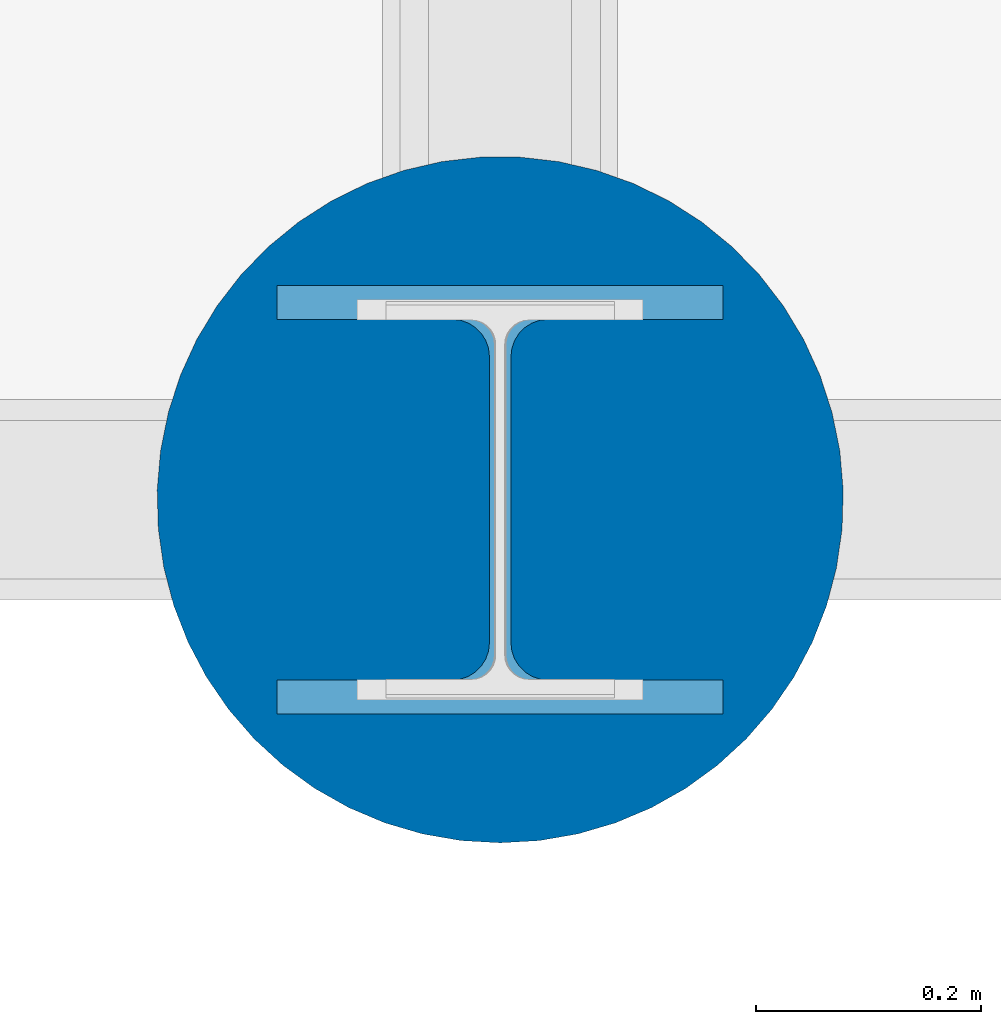
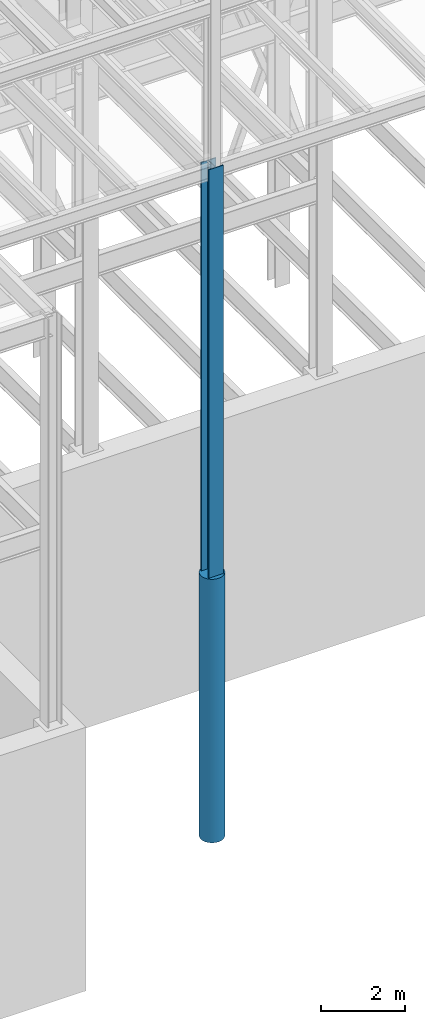
# One storey, part 29 of 150: 2 columns.
"""IFC2X3 building model written with IfcOpenShell, lengths in millimetres."""

from ifc_helpers import new_model, si_unit, frame, origin_with_axes, origin_2d_with_axis, place, context, subcontext, project, spatial, circle, i_section, extrude, material, type_object, element, save


model = new_model("IFC2X3")

# Units and contexts
model_context = context("Model", 3, precision=1e-05, world=origin_with_axes())
body_context = subcontext(model_context, "Body", "Model", "MODEL_VIEW")
ifc_project = project(units=[si_unit("LENGTHUNIT", "METRE", prefix="MILLI"), si_unit("AREAUNIT", "SQUARE_METRE"), si_unit("VOLUMEUNIT", "CUBIC_METRE"), si_unit("MASSUNIT", "GRAM", prefix="KILO"), si_unit("TIMEUNIT", "SECOND"), si_unit("PLANEANGLEUNIT", "RADIAN"), si_unit("SOLIDANGLEUNIT", "STERADIAN"), si_unit("THERMODYNAMICTEMPERATUREUNIT", "DEGREE_CELSIUS"), si_unit("LUMINOUSINTENSITYUNIT", "LUMEN")], contexts=[model_context])

# Site, building, storey
site_placement = place(None, origin_with_axes())
site = spatial("IfcSite", under=ifc_project, at=site_placement, CompositionType="ELEMENT")
building_placement = place(site_placement, origin_with_axes())
building = spatial("IfcBuilding", under=site, at=building_placement, Name="Undefined", CompositionType="ELEMENT")
storey_placement = place(building_placement, origin_with_axes())
storey = spatial("IfcBuildingStorey", under=building, at=storey_placement, Name="Undefined", CompositionType="ELEMENT", Elevation=0.0)

# Columns
ifc_material_1 = material(Name="STEEL/A992")
column_type_1 = type_object("IfcColumnType", Name="W14X159", PredefinedType="NOTDEFINED")
column_1_placement = place(storey_placement, frame((50190.4, 3454.4, 23774.4), z_axis=(0.0, 0.0, 1.0), x_axis=(1.0, 0.0, 0.0)))
element("IfcColumn", 1, at=column_1_placement, inside=storey, type_object=column_type_1, material=ifc_material_1, Name="COLUMN", ObjectType="W14X159", context=body_context, shape_type="SweptSolid", body=[
    extrude(i_section(OverallWidth=396.24, OverallDepth=381.0, WebThickness=19.0499, FlangeThickness=30.226, FilletRadius=33.2739, at=origin_2d_with_axis()), frame((0.0, 0.0, 11811.0), z_axis=(0.0, 0.0, -1.0), x_axis=(-1.0, 0.0, 0.0)), (0.0, 0.0, 1.0), 11811.0),
])
ifc_material_2 = material(Name="CONCRETE/5000")
column_type_2 = type_object("IfcColumnType", PredefinedType="NOTDEFINED")
column_2_placement = place(storey_placement, frame((50190.4, 3454.4, 16154.4), z_axis=(0.0, 0.0, 1.0), x_axis=(1.0, 0.0, 0.0)))
element("IfcColumn", 2, at=column_2_placement, inside=storey, type_object=column_type_2, material=ifc_material_2, Name="COLUMN", context=body_context, shape_type="SweptSolid", body=[
    extrude(circle(Radius=304.8, at=origin_2d_with_axis()), frame((0.0, 0.0, 7620.0), z_axis=(0.0, 0.0, -1.0), x_axis=(0.0, -1.0, 0.0)), (0.0, 0.0, 1.0), 7620.0),
])

save(model, "model.ifc")
